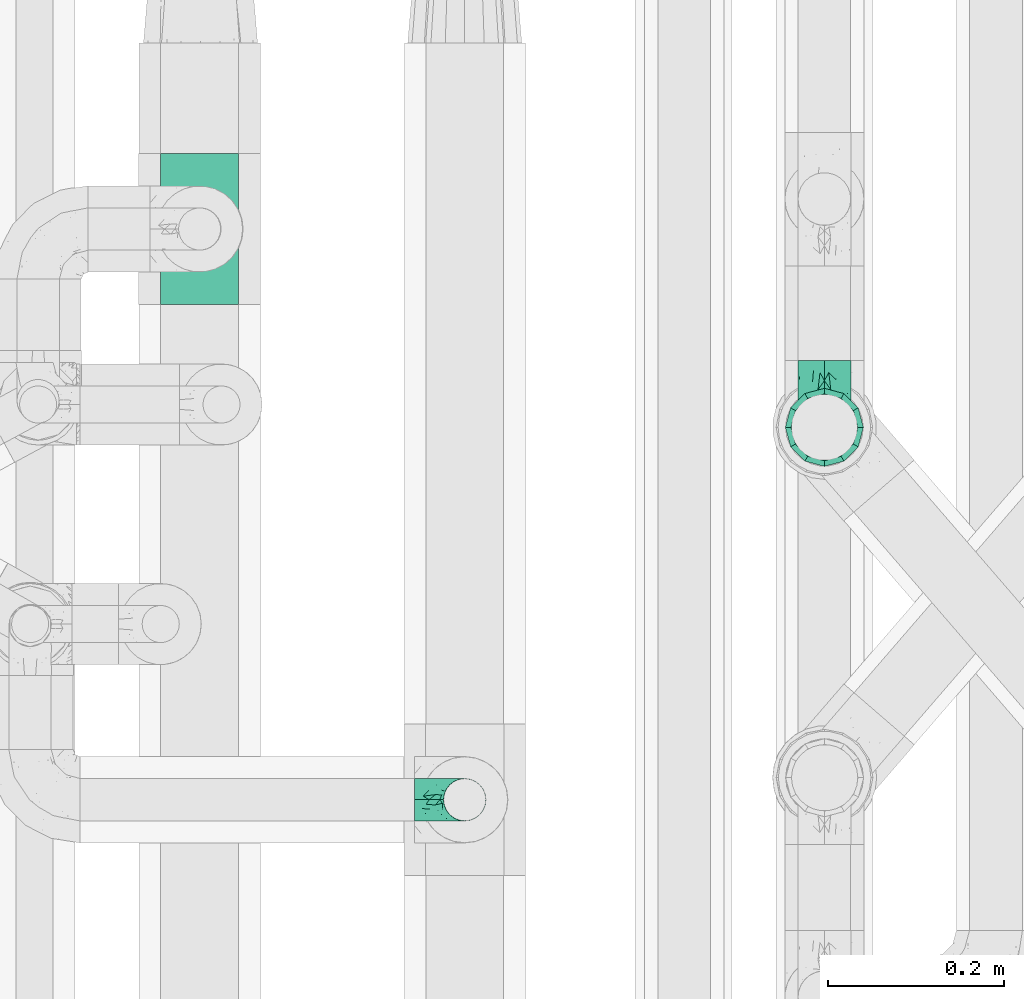
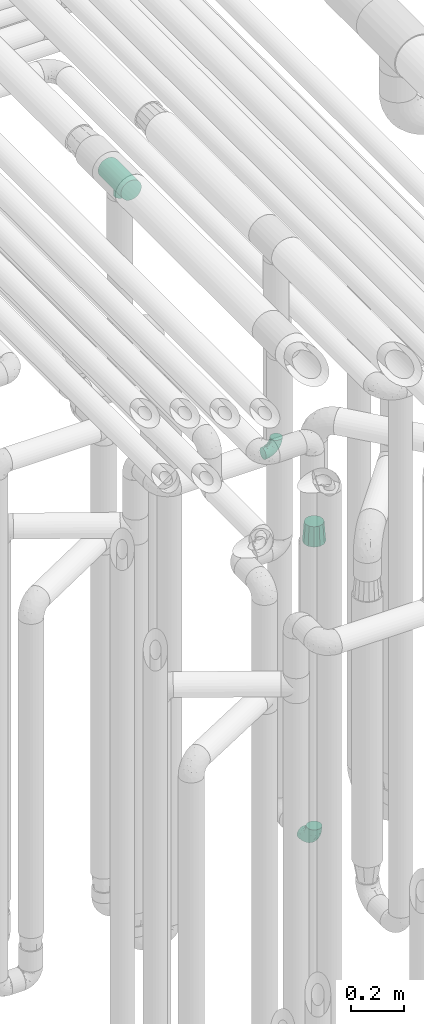
# One storey, part 623 of 824: 4 flow fittings.
"""IFC2X3 building model written with IfcOpenShell, lengths in millimetres."""

from ifc_helpers import new_model, entity, si_unit, converted_unit, derived_unit, direction, frame, origin, place, context, subcontext, project, spatial, faceted_brep, source, transform, mapped, material, type_object, type_shapes, element, save


model = new_model("IFC2X3")

# Units and contexts
model_context = context("Model", 3, precision=0.01, world=origin(), true_north=direction((6.12303176911189e-17, 1.0)))
body_context = subcontext(model_context, "Body", "Model", "MODEL_VIEW")
ifc_project = project(units=[si_unit("LENGTHUNIT", "METRE", prefix="MILLI"), si_unit("AREAUNIT", "SQUARE_METRE"), si_unit("VOLUMEUNIT", "CUBIC_METRE"), converted_unit("PLANEANGLEUNIT", "DEGREE", entity("IfcRatioMeasure", 0.0174532925199433), si_unit("PLANEANGLEUNIT", "RADIAN"), dimensions=[0, 0, 0, 0, 0, 0, 0]), si_unit("MASSUNIT", "GRAM", prefix="KILO"), derived_unit("MASSDENSITYUNIT", [(si_unit("MASSUNIT", "GRAM", prefix="KILO"), 1), (si_unit("LENGTHUNIT", "METRE"), -3)]), derived_unit("MOMENTOFINERTIAUNIT", [(si_unit("LENGTHUNIT", "METRE"), 4)]), si_unit("TIMEUNIT", "SECOND"), si_unit("FREQUENCYUNIT", "HERTZ"), si_unit("THERMODYNAMICTEMPERATUREUNIT", "DEGREE_CELSIUS"), derived_unit("THERMALTRANSMITTANCEUNIT", [(si_unit("MASSUNIT", "GRAM", prefix="KILO"), 1), (si_unit("THERMODYNAMICTEMPERATUREUNIT", "KELVIN"), -1), (si_unit("TIMEUNIT", "SECOND"), -3)]), derived_unit("VOLUMETRICFLOWRATEUNIT", [(si_unit("LENGTHUNIT", "METRE"), 3), (si_unit("TIMEUNIT", "SECOND"), -1)]), derived_unit("MASSFLOWRATEUNIT", [(si_unit("MASSUNIT", "GRAM", prefix="KILO"), 1), (si_unit("TIMEUNIT", "SECOND"), -1)]), derived_unit("ROTATIONALFREQUENCYUNIT", [(si_unit("TIMEUNIT", "SECOND"), -1)]), si_unit("ELECTRICCURRENTUNIT", "AMPERE"), si_unit("ELECTRICVOLTAGEUNIT", "VOLT"), si_unit("POWERUNIT", "WATT"), si_unit("FORCEUNIT", "NEWTON", prefix="KILO"), si_unit("ILLUMINANCEUNIT", "LUX"), si_unit("LUMINOUSFLUXUNIT", "LUMEN"), si_unit("LUMINOUSINTENSITYUNIT", "CANDELA"), derived_unit("USERDEFINED", [(si_unit("MASSUNIT", "GRAM", prefix="KILO"), -1), (si_unit("LENGTHUNIT", "METRE"), -2), (si_unit("TIMEUNIT", "SECOND"), 3), (si_unit("LUMINOUSFLUXUNIT", "LUMEN"), 1)]), derived_unit("LINEARVELOCITYUNIT", [(si_unit("LENGTHUNIT", "METRE"), 1), (si_unit("TIMEUNIT", "SECOND"), -1)]), si_unit("PRESSUREUNIT", "PASCAL"), derived_unit("USERDEFINED", [(si_unit("LENGTHUNIT", "METRE"), -2), (si_unit("MASSUNIT", "GRAM", prefix="KILO"), 1), (si_unit("TIMEUNIT", "SECOND"), -2)]), derived_unit("LINEARFORCEUNIT", [(si_unit("MASSUNIT", "GRAM", prefix="KILO"), 1), (si_unit("LENGTHUNIT", "METRE"), 1), (si_unit("TIMEUNIT", "SECOND"), -2), (si_unit("LENGTHUNIT", "METRE"), -1)]), derived_unit("PLANARFORCEUNIT", [(si_unit("MASSUNIT", "GRAM", prefix="KILO"), 1), (si_unit("LENGTHUNIT", "METRE"), 1), (si_unit("TIMEUNIT", "SECOND"), -2), (si_unit("LENGTHUNIT", "METRE"), -2)])], contexts=[model_context])

# Site, building, storey
site_placement = place(None, origin())
site = spatial("IfcSite", under=ifc_project, at=site_placement, CompositionType="ELEMENT")
building_placement = place(site_placement, origin())
building = spatial("IfcBuilding", under=site, at=building_placement, CompositionType="ELEMENT")
storey_placement = place(building_placement, frame((0.0, 0.0, 28200.0)))
storey = spatial("IfcBuildingStorey", under=building, at=storey_placement, CompositionType="ELEMENT", Elevation=28200.0)

# Flow fittings
ifc_material = material()
pipe_fitting_type_1 = type_object("IfcPipeFittingType", PredefinedType="NOTDEFINED", material=ifc_material)
shared_shape_1 = source(origin(), body_context, "Body", "Brep", [
    faceted_brep([(-57.0, 12.07, -20.91), (-57.0, 6.25, -23.33), (-57.0, 0.0, -24.15), (-57.0, -6.25, -23.33), (-57.0, -12.08, -20.91), (-57.0, -17.08, -17.08), (-57.0, -20.91, -12.08), (-57.0, -23.33, -6.25), (-57.0, -24.15, 0.0), (-57.0, -23.33, 6.25), (-57.0, -20.91, 12.07), (-57.0, -17.08, 17.08), (-57.0, -12.08, 20.91), (-57.0, -6.25, 23.33), (-57.0, 0.0, 24.15), (-57.0, 6.25, 23.33), (-57.0, 12.07, 20.91), (-57.0, 17.08, 17.08), (-57.0, 20.91, 12.07), (-57.0, 23.33, 6.25), (-57.0, 24.15, 0.0), (-57.0, 23.33, -6.25), (-57.0, 20.91, -12.08), (-57.0, 17.08, -17.08), (0.0, 57.0, -24.15), (-6.25, 57.0, -23.33), (-12.07, 57.0, -20.91), (-17.08, 57.0, -17.08), (-20.91, 57.0, -12.08), (-23.33, 57.0, -6.25), (-24.15, 57.0, 0.0), (-23.33, 57.0, 6.25), (-20.91, 57.0, 12.07), (-17.08, 57.0, 17.08), (-12.07, 57.0, 20.91), (-6.25, 57.0, 23.33), (0.0, 57.0, 24.15), (6.25, 57.0, 23.33), (12.08, 57.0, 20.91), (17.08, 57.0, 17.08), (20.91, 57.0, 12.07), (23.33, 57.0, 6.25), (24.15, 57.0, 0.0), (23.33, 57.0, -6.25), (20.91, 57.0, -12.08), (17.08, 57.0, -17.08), (12.08, 57.0, -20.91), (6.25, 57.0, -23.33), (14.9, 21.14, 6.17), (13.61, 24.64, 12.48), (6.23, 8.95, 8.98), (-41.47, -21.06, 0.0), (-41.92, -18.38, 13.72), (-24.64, -13.61, 12.48), (-37.37, -13.24, 18.15), (-6.8, -4.93, 8.18), (-21.76, -15.19, 6.22), (-12.78, -9.18, 0.0), (-37.73, -20.51, 7.75), (-7.38, 7.38, 20.24), (-23.37, -4.26, 20.42), (-11.9, -3.19, 15.86), (-42.14, -8.7, 21.82), (13.24, 37.37, 18.15), (9.33, 23.53, 16.85), (4.26, 23.37, 20.42), (2.77, 10.92, 15.55), (-29.46, 0.91, 23.52), (-44.13, 20.56, 15.69), (-39.25, 26.33, 10.88), (-49.02, 22.92, 9.96), (-34.58, 23.87, 17.15), (-15.8, 6.8, 22.81), (-8.67, 20.47, 23.88), (-18.12, 12.9, 24.08), (-48.29, 14.92, 19.65), (-44.06, -2.85, 23.78), (-9.23, 48.95, 22.58), (-3.78, 42.74, 24.07), (-40.34, 4.26, 24.09), (-44.02, 26.14, 5.46), (-44.04, 9.88, 22.74), (-4.95, 16.87, 22.52), (-2.75, 1.43, 12.5), (-25.48, 40.98, 10.71), (20.51, 37.73, 7.75), (18.38, 41.92, 13.72), (8.7, 42.14, 21.82), (-25.95, -17.97, 0.0), (2.85, 44.06, 23.78), (21.06, 41.47, 0.0), (17.97, 25.95, 0.0), (-24.04, -9.27, 17.13), (-33.26, 33.26, 5.86), (-28.55, 40.57, 0.0), (-40.57, 28.55, 0.0), (-25.29, 47.19, 4.06), (-27.01, 31.1, 16.77), (-15.7, 43.95, 19.9), (-20.27, 45.22, 15.61), (-30.53, 31.98, 12.64), (-11.28, 38.33, 22.92), (-9.97, 27.88, 24.09), (-20.15, 30.26, 21.25), (-31.25, 11.75, 23.64), (-28.75, 7.23, 24.15), (-29.53, 18.06, 22.27), (-28.44, 24.21, 20.02), (-37.55, 17.7, 20.26), (-15.88, 29.25, 22.99), (-20.82, 20.82, 23.44), (-0.91, 29.46, 23.52), (-13.5, -7.67, 12.04), (1.49, 1.56, 5.16), (8.86, 10.35, 4.59), (0.38, -0.38, 0.0), (9.18, 12.78, 0.0), (-37.37, -13.24, -18.15), (8.86, 10.35, -4.59), (-45.22, 20.27, -15.61), (-43.95, 15.7, -19.9), (-38.33, 11.28, -22.92), (-48.95, 9.23, -22.58), (-47.19, 25.29, -4.06), (-33.26, 33.26, -5.86), (18.38, 41.92, -13.72), (-30.26, 20.15, -21.25), (2.85, 44.06, -23.78), (-4.26, 40.34, -24.09), (-40.98, 25.48, -10.71), (-41.92, -18.38, -13.72), (9.25, 23.5, -16.92), (4.26, 23.37, -20.42), (13.24, 37.37, -18.15), (-37.73, -20.51, -7.75), (-11.75, 31.25, -23.64), (-7.23, 28.75, -24.15), (-12.9, 18.12, -24.08), (8.7, 42.14, -21.82), (-44.06, -2.85, -23.78), (-6.8, 15.8, -22.81), (-20.47, 8.67, -23.88), (-24.64, -13.61, -12.48), (-42.74, 3.78, -24.07), (-18.06, 29.53, -22.27), (-24.21, 28.44, -20.02), (-27.88, 9.97, -24.09), (-31.1, 27.01, -16.77), (-26.14, 44.02, -5.46), (14.9, 21.14, -6.17), (20.51, 37.73, -7.75), (-9.88, 44.04, -22.74), (-20.56, 44.13, -15.69), (-21.76, -15.19, -6.22), (-13.5, -7.67, -12.04), (-24.14, -9.76, -16.74), (-11.9, -3.19, -15.86), (-14.92, 48.29, -19.65), (-23.37, -4.26, -20.42), (-0.91, 29.46, -23.52), (-26.33, 39.25, -10.88), (-23.87, 34.58, -17.15), (-42.14, -8.7, -21.82), (-22.92, 49.02, -9.96), (13.61, 24.64, -12.48), (-31.98, 30.53, -12.64), (-16.87, 4.95, -22.52), (-17.7, 37.55, -20.26), (-29.25, 15.88, -22.99), (-20.82, 20.82, -23.44), (-29.46, 0.91, -23.52), (-7.38, 7.38, -20.24), (2.77, 10.92, -15.55), (6.23, 8.95, -8.98), (-6.8, -4.93, -8.18), (-2.81, 1.41, -12.54), (1.49, 1.56, -5.16)], [[[0, 1, 2, 3, 4, 5, 6, 7, 8, 9, 10, 11, 12, 13, 14, 15, 16, 17, 18, 19, 20, 21, 22, 23]], [[24, 25, 26, 27, 28, 29, 30, 31, 32, 33, 34, 35, 36, 37, 38, 39, 40, 41, 42, 43, 44, 45, 46, 47]], [[48, 49, 50]], [[9, 8, 51]], [[52, 53, 54]], [[55, 56, 57]], [[10, 58, 52]], [[9, 58, 10]], [[59, 60, 61]], [[54, 12, 11]], [[54, 62, 12]], [[63, 39, 38]], [[64, 65, 66]], [[62, 60, 67]], [[68, 69, 70]], [[71, 69, 68]], [[72, 73, 74]], [[16, 75, 17]], [[13, 76, 14]], [[35, 77, 78]], [[14, 79, 15]], [[17, 68, 18]], [[14, 76, 79]], [[20, 19, 80]], [[70, 19, 18]], [[81, 15, 79]], [[15, 81, 16]], [[73, 72, 82]], [[66, 83, 50]], [[32, 31, 84]], [[85, 86, 49]], [[63, 87, 65]], [[56, 58, 88]], [[36, 89, 37]], [[85, 41, 40]], [[36, 35, 78]], [[90, 41, 85]], [[40, 39, 86]], [[12, 62, 13]], [[86, 85, 40]], [[48, 85, 49]], [[85, 91, 90]], [[87, 38, 37]], [[92, 60, 54]], [[80, 69, 93]], [[93, 94, 95]], [[10, 52, 11]], [[94, 96, 30]], [[97, 98, 99]], [[80, 93, 95]], [[100, 97, 84]], [[99, 98, 33]], [[101, 102, 78]], [[103, 101, 98]], [[96, 31, 30]], [[77, 98, 101]], [[77, 35, 34]], [[34, 33, 98]], [[9, 51, 58]], [[87, 63, 38]], [[104, 105, 74]], [[106, 103, 107]], [[106, 81, 104]], [[75, 68, 17]], [[108, 107, 71]], [[33, 32, 99]], [[109, 103, 110]], [[101, 109, 102]], [[89, 78, 111]], [[53, 52, 58]], [[54, 11, 52]], [[60, 62, 54]], [[88, 58, 51]], [[76, 62, 67]], [[53, 112, 92]], [[60, 59, 72]], [[39, 63, 86]], [[49, 86, 63]], [[89, 87, 37]], [[42, 41, 90]], [[111, 82, 65]], [[111, 65, 87]], [[65, 59, 66]], [[104, 81, 79]], [[75, 81, 108]], [[32, 84, 99]], [[97, 99, 84]], [[98, 97, 103]], [[106, 107, 108]], [[74, 102, 110]], [[111, 78, 102]], [[74, 110, 104]], [[74, 67, 72]], [[61, 92, 112]], [[66, 59, 61]], [[56, 53, 58]], [[66, 50, 49]], [[61, 112, 83]], [[66, 49, 64]], [[78, 89, 36]], [[87, 89, 111]], [[62, 76, 13]], [[79, 76, 67]], [[100, 93, 69]], [[96, 93, 84]], [[55, 113, 50]], [[113, 114, 50]], [[104, 79, 105]], [[106, 104, 110]], [[20, 80, 95]], [[85, 48, 91]], [[115, 114, 113]], [[116, 91, 48]], [[70, 80, 19]], [[93, 96, 94]], [[84, 31, 96]], [[103, 106, 110]], [[81, 106, 108]], [[103, 97, 107]], [[71, 107, 97]], [[71, 97, 100]], [[108, 71, 68]], [[79, 67, 105]], [[67, 74, 105]], [[115, 113, 57]], [[112, 56, 55]], [[56, 88, 57]], [[60, 72, 67]], [[82, 72, 59]], [[65, 82, 59]], [[82, 111, 73]], [[111, 102, 73]], [[102, 74, 73]], [[81, 75, 16]], [[68, 75, 108]], [[68, 70, 18]], [[80, 70, 69]], [[98, 77, 34]], [[78, 77, 101]], [[93, 100, 84]], [[71, 100, 69]], [[102, 109, 110]], [[101, 103, 109]], [[53, 92, 54]], [[61, 60, 92]], [[56, 112, 53]], [[83, 112, 55]], [[50, 83, 55]], [[61, 83, 66]], [[49, 63, 64]], [[65, 64, 63]], [[57, 113, 55]], [[114, 115, 116]], [[116, 48, 114]], [[48, 50, 114]], [[117, 5, 4]], [[116, 115, 118]], [[119, 120, 23]], [[121, 122, 120]], [[95, 123, 20]], [[0, 23, 120]], [[124, 95, 94]], [[125, 45, 44]], [[121, 120, 126]], [[24, 127, 128]], [[22, 21, 129]], [[0, 122, 1]], [[5, 117, 130]], [[131, 132, 133]], [[134, 88, 51]], [[135, 136, 137]], [[6, 5, 130]], [[46, 138, 47]], [[139, 3, 2]], [[140, 141, 137]], [[6, 134, 7]], [[134, 130, 142]], [[143, 2, 1]], [[144, 126, 145]], [[121, 146, 143]], [[147, 120, 119]], [[94, 148, 124]], [[149, 150, 91]], [[30, 29, 148]], [[151, 25, 128]], [[27, 152, 28]], [[134, 153, 88]], [[154, 155, 156]], [[27, 26, 157]], [[151, 26, 25]], [[155, 158, 156]], [[24, 47, 127]], [[1, 122, 143]], [[138, 132, 159]], [[160, 152, 161]], [[24, 128, 25]], [[46, 133, 138]], [[162, 117, 4]], [[148, 160, 124]], [[152, 160, 163]], [[154, 142, 155]], [[45, 125, 133]], [[133, 46, 45]], [[125, 164, 133]], [[51, 7, 134]], [[42, 90, 43]], [[165, 147, 129]], [[153, 134, 142]], [[43, 150, 44]], [[162, 4, 3]], [[141, 140, 166]], [[117, 162, 158]], [[163, 29, 28]], [[43, 90, 150]], [[123, 21, 20]], [[144, 151, 135]], [[157, 152, 27]], [[167, 145, 161]], [[23, 22, 119]], [[168, 126, 169]], [[121, 168, 146]], [[139, 143, 170]], [[142, 130, 117]], [[8, 7, 51]], [[134, 6, 130]], [[139, 162, 3]], [[170, 166, 158]], [[170, 158, 162]], [[158, 171, 156]], [[44, 150, 125]], [[91, 150, 90]], [[164, 125, 150]], [[132, 138, 133]], [[127, 138, 159]], [[131, 164, 172]], [[132, 171, 140]], [[135, 151, 128]], [[157, 151, 167]], [[22, 129, 119]], [[147, 119, 129]], [[120, 147, 126]], [[144, 145, 167]], [[137, 146, 169]], [[170, 143, 146]], [[137, 169, 135]], [[137, 159, 140]], [[171, 172, 156]], [[173, 174, 175]], [[156, 175, 154]], [[174, 57, 153]], [[132, 172, 171]], [[172, 164, 173]], [[143, 139, 2]], [[162, 139, 170]], [[138, 127, 47]], [[128, 127, 159]], [[165, 124, 160]], [[123, 124, 129]], [[149, 173, 164]], [[176, 174, 173]], [[135, 128, 136]], [[144, 135, 169]], [[150, 149, 164]], [[176, 118, 115]], [[149, 91, 116]], [[30, 148, 94]], [[163, 148, 29]], [[124, 123, 95]], [[129, 21, 123]], [[126, 144, 169]], [[151, 144, 167]], [[126, 147, 145]], [[161, 145, 147]], [[161, 147, 165]], [[167, 161, 152]], [[128, 159, 136]], [[159, 137, 136]], [[154, 153, 142]], [[132, 140, 159]], [[174, 176, 57]], [[57, 88, 153]], [[166, 140, 171]], [[158, 166, 171]], [[166, 170, 141]], [[170, 146, 141]], [[146, 137, 141]], [[151, 157, 26]], [[152, 157, 167]], [[152, 163, 28]], [[148, 163, 160]], [[120, 122, 0]], [[143, 122, 121]], [[124, 165, 129]], [[161, 165, 160]], [[146, 168, 169]], [[121, 126, 168]], [[142, 117, 155]], [[158, 155, 117]], [[175, 156, 172]], [[153, 154, 174]], [[173, 175, 172]], [[174, 154, 175]], [[164, 131, 133]], [[172, 132, 131]], [[176, 173, 118]], [[57, 176, 115]], [[173, 149, 118]], [[149, 116, 118]]]),
])
type_shapes(pipe_fitting_type_1, [shared_shape_1])
flow_fitting_1_placement = place(storey_placement, frame((36220.03, 12556.08, 2600.0), z_axis=(0.0, -1.0, 0.0), x_axis=(1.0, 0.0, 0.0)))
element("IfcFlowFitting", 1, at=flow_fitting_1_placement, inside=storey, type_object=pipe_fitting_type_1, material=ifc_material, context=body_context, shape_type="MappedRepresentation", body=[
    mapped(shared_shape_1, transform((0.0, 0.0, 0.0), scale=1.0)),
])
pipe_fitting_type_2 = type_object("IfcPipeFittingType", PredefinedType="NOTDEFINED", material=ifc_material)
shared_shape_2 = source(origin(), body_context, "Body", "Brep", [
    faceted_brep([(-76.0, 15.07, -26.11), (-76.0, 7.8, -29.12), (-76.0, 0.0, -30.15), (-76.0, -7.8, -29.12), (-76.0, -15.08, -26.11), (-76.0, -21.32, -21.32), (-76.0, -26.11, -15.08), (-76.0, -29.12, -7.8), (-76.0, -30.15, 0.0), (-76.0, -29.12, 7.8), (-76.0, -26.11, 15.07), (-76.0, -21.32, 21.32), (-76.0, -15.08, 26.11), (-76.0, -7.8, 29.12), (-76.0, 0.0, 30.15), (-76.0, 7.8, 29.12), (-76.0, 15.07, 26.11), (-76.0, 21.32, 21.32), (-76.0, 26.11, 15.07), (-76.0, 29.12, 7.8), (-76.0, 30.15, 0.0), (-76.0, 29.12, -7.8), (-76.0, 26.11, -15.08), (-76.0, 21.32, -21.32), (0.0, 76.0, -30.15), (-7.8, 76.0, -29.12), (-15.07, 76.0, -26.11), (-21.32, 76.0, -21.32), (-26.11, 76.0, -15.08), (-29.12, 76.0, -7.8), (-30.15, 76.0, 0.0), (-29.12, 76.0, 7.8), (-26.11, 76.0, 15.07), (-21.32, 76.0, 21.32), (-15.07, 76.0, 26.11), (-7.8, 76.0, 29.12), (0.0, 76.0, 30.15), (7.8, 76.0, 29.12), (15.08, 76.0, 26.11), (21.32, 76.0, 21.32), (26.11, 76.0, 15.07), (29.12, 76.0, 7.8), (30.15, 76.0, 0.0), (29.12, 76.0, -7.8), (26.11, 76.0, -15.08), (21.32, 76.0, -21.32), (15.08, 76.0, -26.11), (7.8, 76.0, -29.12), (10.79, 31.43, 21.07), (4.32, 31.7, 25.72), (1.65, 15.19, 19.92), (-61.17, -27.8, 0.0), (-51.1, -25.49, 9.84), (-56.14, -10.61, 27.27), (-31.7, -4.32, 25.72), (-39.75, 1.72, 29.41), (-43.2, -24.95, 0.0), (-1.86, 1.86, 0.0), (4.49, 7.65, 5.78), (-7.82, -4.61, 5.83), (-56.21, -22.79, 17.21), (-58.98, -3.38, 29.7), (-53.96, 5.6, 30.07), (-10.86, 10.86, 25.48), (-17.2, -2.6, 20.44), (-49.15, -16.01, 22.7), (-22.18, -14.24, 7.99), (-28.4, -17.42, 0.0), (-13.61, -9.88, 0.0), (-39.0, 23.48, 27.76), (-58.76, 12.54, 28.36), (-41.61, 15.41, 29.48), (16.01, 49.15, 22.7), (-58.55, 25.93, 19.53), (-51.53, 33.5, 13.51), (-64.92, 28.76, 12.4), (-7.48, 23.14, 28.25), (-1.72, 39.75, 29.41), (-12.04, 27.88, 29.88), (-63.91, 18.81, 24.52), (-11.63, 65.16, 28.18), (-4.97, 57.02, 30.05), (9.88, 13.61, 0.0), (-62.5, 31.74, 5.02), (-45.17, 30.98, 21.2), (-21.78, 9.76, 28.58), (10.61, 56.14, 27.27), (-32.09, 54.42, 13.26), (22.79, 56.21, 17.21), (15.38, 31.17, 15.63), (25.49, 51.1, 9.84), (21.84, 36.35, 5.92), (24.95, 43.2, 0.0), (3.38, 58.98, 29.7), (-31.17, -15.38, 15.63), (-39.39, 41.78, 15.45), (-34.56, 41.13, 20.79), (-39.81, -23.25, 5.49), (27.8, 61.17, 0.0), (-31.74, 62.5, 5.02), (-53.07, 36.29, 0.0), (-42.95, 42.95, 7.29), (-36.29, 53.07, 0.0), (-19.83, 58.51, 24.79), (-25.48, 60.2, 19.41), (-14.53, 50.96, 28.57), (-13.31, 37.09, 30.07), (-26.16, 40.06, 26.4), (-32.43, -10.35, 21.9), (17.42, 28.4, 0.0), (14.24, 22.18, 7.99), (-38.67, 9.72, 30.15), (-24.66, 17.36, 30.09), (-37.08, 31.49, 24.99), (-49.27, 22.83, 25.24), (-20.8, 38.81, 28.63), (-27.58, 27.58, 29.2), (-36.07, -20.23, 10.71), (-15.19, -6.16, 14.9), (6.6, 15.4, 14.49), (-2.51, 2.51, 11.35), (-65.16, 11.63, -28.18), (-49.15, -16.01, -22.7), (-57.02, 4.97, -30.05), (-25.93, 58.55, -19.53), (-33.5, 51.53, -13.51), (-28.76, 64.92, -12.4), (-60.2, 25.48, -19.41), (-58.51, 19.83, -24.79), (4.61, 7.82, -5.83), (-7.65, -4.49, -5.78), (-2.51, 2.51, -11.35), (-62.5, 31.74, -5.02), (-50.96, 14.53, -28.57), (-37.09, 13.31, -30.07), (-42.95, 42.95, -7.29), (25.49, 51.1, -9.84), (22.79, 56.21, -17.21), (-40.06, 26.16, -26.4), (3.38, 58.98, -29.7), (-5.6, 53.96, -30.07), (-27.88, 12.04, -29.88), (-9.76, 21.78, -28.58), (-23.14, 7.48, -28.25), (-51.1, -25.49, -9.84), (15.38, 31.17, -15.63), (16.01, 49.15, -22.7), (-23.48, 39.0, -27.76), (-12.54, 58.76, -28.36), (-15.41, 41.61, -29.48), (-56.21, -22.79, -17.21), (-9.72, 38.67, -30.15), (-17.36, 24.66, -30.09), (-22.18, -14.24, -7.99), (-41.13, 34.56, -20.79), (-31.74, 62.5, -5.02), (-58.98, -3.38, -29.7), (-31.17, -15.38, -15.63), (-56.14, -10.61, -27.27), (14.24, 22.18, -7.99), (23.25, 39.81, -5.49), (-31.49, 37.08, -24.99), (-15.19, -6.16, -14.9), (1.65, 15.19, -19.92), (-18.81, 63.91, -24.52), (-32.59, -11.62, -20.84), (-31.7, -4.32, -25.72), (-17.2, -2.6, -20.44), (-39.75, 1.72, -29.41), (-54.42, 32.09, -13.26), (-30.98, 45.17, -21.2), (10.61, 56.14, -27.27), (10.23, 31.31, -21.52), (4.32, 31.7, -25.72), (-41.78, 39.39, -15.45), (-1.72, 39.75, -29.41), (-36.35, -21.84, -5.92), (-22.83, 49.27, -25.24), (-38.81, 20.8, -28.63), (-27.58, 27.58, -29.2), (-10.86, 10.86, -25.48), (20.23, 36.07, -10.71), (6.6, 15.4, -14.49)], [[[0, 1, 2, 3, 4, 5, 6, 7, 8, 9, 10, 11, 12, 13, 14, 15, 16, 17, 18, 19, 20, 21, 22, 23]], [[24, 25, 26, 27, 28, 29, 30, 31, 32, 33, 34, 35, 36, 37, 38, 39, 40, 41, 42, 43, 44, 45, 46, 47]], [[48, 49, 50]], [[51, 52, 9]], [[53, 54, 55]], [[9, 52, 10]], [[56, 52, 51]], [[57, 58, 59]], [[11, 10, 60]], [[14, 61, 62]], [[63, 54, 64]], [[65, 12, 11]], [[65, 53, 12]], [[66, 67, 68]], [[69, 70, 71]], [[72, 39, 38]], [[73, 74, 75]], [[15, 70, 16]], [[76, 77, 78]], [[16, 79, 17]], [[13, 61, 14]], [[35, 80, 81]], [[14, 62, 15]], [[17, 73, 18]], [[57, 82, 58]], [[20, 19, 83]], [[75, 19, 18]], [[70, 15, 62]], [[73, 84, 74]], [[78, 85, 76]], [[38, 86, 72]], [[32, 31, 87]], [[88, 89, 90]], [[91, 92, 90]], [[72, 86, 49]], [[36, 93, 37]], [[75, 83, 19]], [[36, 35, 81]], [[60, 94, 65]], [[40, 90, 41]], [[95, 96, 87]], [[88, 90, 40]], [[66, 97, 67]], [[90, 98, 41]], [[40, 39, 88]], [[99, 31, 30]], [[20, 83, 100]], [[101, 102, 100]], [[52, 60, 10]], [[102, 99, 30]], [[96, 103, 104]], [[83, 101, 100]], [[12, 53, 13]], [[104, 103, 33]], [[105, 106, 81]], [[107, 105, 103]], [[64, 54, 108]], [[80, 103, 105]], [[80, 35, 34]], [[34, 33, 103]], [[86, 38, 37]], [[109, 110, 82]], [[71, 111, 112]], [[69, 107, 113]], [[79, 73, 17]], [[114, 113, 84]], [[33, 32, 104]], [[115, 107, 116]], [[105, 115, 106]], [[93, 81, 77]], [[54, 53, 65]], [[61, 53, 55]], [[108, 94, 64]], [[54, 63, 85]], [[93, 86, 37]], [[77, 76, 49]], [[77, 49, 86]], [[49, 63, 50]], [[60, 52, 117]], [[65, 11, 60]], [[39, 72, 88]], [[89, 88, 72]], [[71, 70, 62]], [[79, 70, 114]], [[103, 96, 107]], [[69, 113, 114]], [[112, 106, 116]], [[77, 81, 106]], [[112, 116, 71]], [[112, 55, 85]], [[64, 50, 63]], [[57, 59, 68]], [[32, 87, 104]], [[96, 104, 87]], [[94, 118, 64]], [[50, 119, 89]], [[50, 64, 118]], [[50, 89, 48]], [[81, 93, 36]], [[86, 93, 77]], [[53, 61, 13]], [[62, 61, 55]], [[71, 62, 111]], [[69, 71, 116]], [[95, 101, 74]], [[99, 101, 87]], [[118, 66, 59]], [[117, 97, 66]], [[117, 66, 94]], [[91, 89, 110]], [[91, 110, 109]], [[110, 89, 119]], [[9, 8, 51]], [[98, 90, 92]], [[98, 42, 41]], [[101, 83, 74]], [[101, 99, 102]], [[87, 31, 99]], [[62, 55, 111]], [[55, 112, 111]], [[107, 69, 116]], [[70, 69, 114]], [[107, 96, 113]], [[84, 113, 96]], [[84, 96, 95]], [[114, 84, 73]], [[70, 79, 16]], [[73, 79, 114]], [[54, 85, 55]], [[76, 85, 63]], [[49, 76, 63]], [[77, 106, 78]], [[106, 112, 78]], [[85, 78, 112]], [[73, 75, 18]], [[83, 75, 74]], [[103, 80, 34]], [[81, 80, 105]], [[101, 95, 87]], [[84, 95, 74]], [[106, 115, 116]], [[105, 107, 115]], [[120, 59, 58]], [[82, 110, 58]], [[119, 58, 110]], [[118, 59, 120]], [[66, 68, 59]], [[54, 65, 108]], [[94, 108, 65]], [[66, 118, 94]], [[50, 118, 120]], [[50, 120, 119]], [[119, 120, 58]], [[89, 72, 48]], [[49, 48, 72]], [[60, 117, 94]], [[117, 52, 97]], [[52, 56, 97]], [[67, 97, 56]], [[92, 91, 109]], [[89, 91, 90]], [[121, 1, 0]], [[122, 5, 4]], [[2, 1, 123]], [[124, 125, 126]], [[127, 128, 23]], [[129, 130, 131]], [[100, 132, 20]], [[133, 134, 123]], [[135, 100, 102]], [[136, 137, 44]], [[133, 128, 138]], [[24, 139, 140]], [[141, 142, 143]], [[121, 128, 133]], [[6, 144, 7]], [[137, 145, 146]], [[144, 51, 7]], [[147, 148, 149]], [[144, 6, 150]], [[149, 151, 152]], [[153, 68, 67]], [[154, 128, 127]], [[30, 155, 102]], [[43, 42, 98]], [[156, 3, 2]], [[157, 144, 150]], [[158, 4, 3]], [[24, 140, 25]], [[155, 135, 102]], [[159, 160, 109]], [[30, 29, 155]], [[147, 138, 161]], [[27, 124, 28]], [[57, 129, 82]], [[162, 163, 131]], [[27, 26, 164]], [[148, 26, 25]], [[165, 166, 167]], [[24, 47, 139]], [[143, 168, 141]], [[22, 21, 169]], [[125, 124, 170]], [[148, 25, 140]], [[46, 146, 171]], [[158, 122, 4]], [[0, 23, 128]], [[1, 121, 123]], [[109, 82, 159]], [[45, 44, 137]], [[146, 46, 45]], [[136, 43, 98]], [[132, 21, 20]], [[136, 98, 92]], [[172, 173, 146]], [[46, 171, 47]], [[43, 136, 44]], [[174, 154, 169]], [[171, 173, 175]], [[6, 5, 150]], [[126, 29, 28]], [[176, 56, 144]], [[122, 158, 166]], [[164, 124, 27]], [[177, 161, 170]], [[23, 22, 127]], [[178, 138, 179]], [[133, 178, 134]], [[156, 123, 168]], [[156, 158, 3]], [[168, 143, 166]], [[168, 166, 158]], [[166, 180, 167]], [[173, 171, 146]], [[139, 171, 175]], [[172, 145, 163]], [[173, 180, 142]], [[5, 122, 150]], [[157, 150, 122]], [[137, 136, 181]], [[146, 45, 137]], [[149, 148, 140]], [[164, 148, 177]], [[128, 154, 138]], [[147, 161, 177]], [[152, 134, 179]], [[168, 123, 134]], [[152, 179, 149]], [[152, 175, 142]], [[57, 130, 129]], [[157, 165, 167]], [[22, 169, 127]], [[154, 127, 169]], [[163, 167, 180]], [[162, 157, 167]], [[173, 163, 180]], [[182, 163, 145]], [[123, 156, 2]], [[158, 156, 168]], [[171, 139, 47]], [[140, 139, 175]], [[149, 140, 151]], [[147, 149, 179]], [[174, 135, 125]], [[132, 135, 169]], [[176, 157, 153]], [[176, 153, 67]], [[153, 157, 162]], [[182, 159, 129]], [[181, 160, 159]], [[181, 159, 145]], [[51, 144, 56]], [[51, 8, 7]], [[135, 132, 100]], [[169, 21, 132]], [[126, 155, 29]], [[135, 155, 125]], [[140, 175, 151]], [[175, 152, 151]], [[138, 147, 179]], [[148, 147, 177]], [[138, 154, 161]], [[170, 161, 154]], [[170, 154, 174]], [[177, 170, 124]], [[148, 164, 26]], [[124, 164, 177]], [[173, 142, 175]], [[143, 142, 180]], [[166, 143, 180]], [[168, 134, 141]], [[134, 152, 141]], [[142, 141, 152]], [[124, 126, 28]], [[155, 126, 125]], [[128, 121, 0]], [[123, 121, 133]], [[135, 174, 169]], [[170, 174, 125]], [[134, 178, 179]], [[133, 138, 178]], [[130, 153, 162]], [[68, 153, 130]], [[57, 68, 130]], [[182, 129, 131]], [[159, 82, 129]], [[157, 122, 165]], [[166, 165, 122]], [[163, 162, 167]], [[162, 131, 130]], [[145, 172, 146]], [[163, 173, 172]], [[159, 182, 145]], [[131, 163, 182]], [[56, 176, 67]], [[157, 176, 144]], [[137, 181, 145]], [[181, 136, 160]], [[136, 92, 160]], [[109, 160, 92]]]),
])
type_shapes(pipe_fitting_type_2, [shared_shape_2])
flow_fitting_2_placement = place(storey_placement, frame((36629.64, 12980.2, 400.0), z_axis=(-1.0, 0.0, 0.0), x_axis=(0.0, -1.0, 0.0)))
element("IfcFlowFitting", 2, at=flow_fitting_2_placement, inside=storey, type_object=pipe_fitting_type_2, material=ifc_material, context=body_context, shape_type="MappedRepresentation", body=[
    mapped(shared_shape_2, transform((0.0, 0.0, 0.0), scale=1.0)),
])
pipe_fitting_type_3 = type_object("IfcPipeFittingType", PredefinedType="NOTDEFINED", material=ifc_material)
shared_shape_3 = source(origin(), body_context, "Body", "Brep", [
    faceted_brep([(89.0, -44.45, 0.0), (89.0, -41.96, -9.31), (89.0, -38.49, -22.22), (89.0, -30.36, -30.36), (89.0, -22.23, -38.49), (89.0, -11.11, -41.47), (89.0, 0.0, -44.45), (89.0, 11.11, -41.47), (89.0, 22.22, -38.49), (89.0, 30.36, -30.36), (89.0, 38.49, -22.22), (89.0, 41.96, -9.31), (89.0, 44.45, 0.0), (89.0, 41.96, 9.31), (89.0, 38.49, 22.23), (89.0, 30.36, 30.36), (89.0, 22.22, 38.49), (89.0, 11.11, 41.47), (89.0, 0.0, 44.45), (89.0, -11.11, 41.47), (89.0, -22.23, 38.49), (89.0, -30.36, 30.36), (89.0, -38.49, 22.23), (89.0, -41.96, 9.31), (0.0, 38.05, 0.0), (0.0, 35.5, -9.51), (0.0, 32.95, -19.02), (0.0, 25.99, -25.99), (0.0, 19.02, -32.95), (0.0, 9.51, -35.5), (0.0, 0.0, -38.05), (0.0, -9.51, -35.5), (0.0, -19.03, -32.95), (0.0, -25.99, -25.99), (0.0, -32.95, -19.02), (0.0, -35.5, -9.51), (0.0, -38.05, 0.0), (0.0, -35.5, 9.51), (0.0, -32.95, 19.03), (0.0, -25.99, 25.99), (0.0, -19.03, 32.95), (0.0, -9.51, 35.5), (0.0, 0.0, 38.05), (0.0, 9.51, 35.5), (0.0, 19.03, 32.95), (0.0, 25.99, 25.99), (0.0, 32.95, 19.03), (0.0, 35.5, 9.51)], [[[0, 1, 2, 3, 4, 5, 6, 7, 8, 9, 10, 11, 12, 13, 14, 15, 16, 17, 18, 19, 20, 21, 22, 23]], [[24, 25, 26, 27, 28, 29, 30, 31, 32, 33, 34, 35, 36, 37, 38, 39, 40, 41, 42, 43, 44, 45, 46, 47]], [[2, 1, 0, 36, 35, 34]], [[28, 8, 7, 6, 30, 29]], [[32, 4, 3, 2, 34, 33]], [[5, 4, 32, 31, 30, 6]], [[10, 26, 25, 24, 12, 11]], [[9, 8, 28, 27, 26, 10]], [[14, 13, 12, 24, 47, 46]], [[40, 20, 19, 18, 42, 41]], [[44, 16, 15, 14, 46, 45]], [[17, 16, 44, 43, 42, 18]], [[22, 38, 37, 36, 0, 23]], [[21, 20, 40, 39, 38, 22]]]),
])
type_shapes(pipe_fitting_type_3, [shared_shape_3])
flow_fitting_3_placement = place(storey_placement, frame((36629.64, 12980.2, 1870.0), z_axis=(0.0, 1.0, 0.0), x_axis=(0.0, 0.0, -1.0)))
element("IfcFlowFitting", 3, at=flow_fitting_3_placement, inside=storey, type_object=pipe_fitting_type_3, material=ifc_material, context=body_context, shape_type="MappedRepresentation", body=[
    mapped(shared_shape_3, transform((0.0, 0.0, 0.0), scale=1.0)),
])
pipe_fitting_type_4 = type_object("IfcPipeFittingType", PredefinedType="NOTDEFINED", material=ifc_material)
shared_shape_4 = source(origin(), body_context, "Body", "Brep", [
    faceted_brep([(-86.0, 22.22, -38.49), (-86.0, 11.5, -42.94), (-86.0, 0.0, -44.45), (-86.0, -11.5, -42.94), (-86.0, -22.23, -38.49), (-86.0, -31.43, -31.43), (-86.0, -38.49, -22.23), (-86.0, -42.94, -11.5), (-86.0, -44.45, 0.0), (-86.0, -42.94, 11.5), (-86.0, -38.49, 22.22), (-86.0, -31.43, 31.43), (-86.0, -22.23, 38.49), (-86.0, -11.5, 42.94), (-86.0, 0.0, 44.45), (-86.0, 11.5, 42.94), (-86.0, 22.22, 38.49), (-86.0, 31.43, 31.43), (-86.0, 38.49, 22.22), (-86.0, 42.94, 11.5), (-86.0, 44.45, 0.0), (-86.0, 42.94, -11.5), (-86.0, 38.49, -22.23), (-86.0, 31.43, -31.43), (86.0, 0.0, -44.45), (86.0, 11.5, -42.94), (86.0, 22.22, -38.49), (86.0, 31.43, -31.43), (86.0, 38.49, -22.23), (86.0, 42.94, -11.5), (86.0, 44.45, 0.0), (86.0, 42.94, 11.5), (86.0, 38.49, 22.22), (86.0, 31.43, 31.43), (86.0, 22.22, 38.49), (86.0, 11.5, 42.94), (86.0, 0.0, 44.45), (86.0, -11.5, 42.94), (86.0, -22.23, 38.49), (86.0, -31.43, 31.43), (86.0, -38.49, 22.22), (86.0, -42.94, 11.5), (86.0, -44.45, 0.0), (86.0, -42.94, -11.5), (86.0, -38.49, -22.23), (86.0, -31.43, -31.43), (86.0, -22.23, -38.49), (86.0, -11.5, -42.94), (22.65, -43.65, 8.39), (23.4, -44.05, 4.19), (24.15, -44.45, 0.0), (18.45, -41.63, 15.58), (4.27, -37.56, 23.77), (12.15, -39.25, 20.87), (8.21, -38.4, 22.32), (-24.15, -44.45, 0.0), (-23.4, -44.05, 4.19), (-22.65, -43.65, 8.38), (-18.46, -41.63, 15.57), (-12.16, -39.25, 20.87), (-8.22, -38.4, 22.32), (-4.28, -37.56, 23.77), (0.0, -37.56, 23.77), (4.27, -37.56, -23.77), (12.15, -39.25, -20.87), (8.21, -38.4, -22.32), (18.45, -41.63, -15.58), (22.65, -43.65, -8.39), (23.4, -44.05, -4.19), (-4.28, -37.56, -23.77), (-8.22, -38.4, -22.32), (-12.16, -39.25, -20.87), (-18.46, -41.63, -15.57), (0.0, -37.56, -23.77), (-22.65, -43.65, -8.38), (-23.4, -44.05, -4.19), (0.0, -73.0, -24.15), (6.25, -73.0, -23.33), (12.08, -73.0, -20.91), (17.08, -73.0, -17.08), (20.91, -73.0, -12.08), (23.33, -73.0, -6.25), (24.15, -73.0, 0.0), (23.33, -73.0, 6.25), (20.91, -73.0, 12.07), (17.08, -73.0, 17.08), (12.08, -73.0, 20.91), (6.25, -73.0, 23.33), (0.0, -73.0, 24.15), (-6.25, -73.0, 23.33), (-12.07, -73.0, 20.91), (-17.08, -73.0, 17.08), (-20.91, -73.0, 12.07), (-23.33, -73.0, 6.25), (-24.15, -73.0, 0.0), (-23.33, -73.0, -6.25), (-20.91, -73.0, -12.08), (-17.08, -73.0, -17.08), (-12.07, -73.0, -20.91), (-6.25, -73.0, -23.33)], [[[0, 1, 2, 3, 4, 5, 6, 7, 8, 9, 10, 11, 12, 13, 14, 15, 16, 17, 18, 19, 20, 21, 22, 23]], [[24, 25, 26, 27, 28, 29, 30, 31, 32, 33, 34, 35, 36, 37, 38, 39, 40, 41, 42, 43, 44, 45, 46, 47]], [[42, 41, 48]], [[42, 48, 49, 50]], [[41, 51, 48]], [[40, 39, 52]], [[53, 51, 40]], [[40, 52, 54, 53]], [[39, 11, 52]], [[40, 51, 41]], [[8, 55, 56, 57]], [[9, 8, 57]], [[57, 58, 9]], [[10, 59, 60, 61]], [[59, 10, 58]], [[10, 61, 11]], [[58, 10, 9]], [[11, 61, 62, 52]], [[39, 38, 12, 11]], [[14, 13, 37, 36]], [[13, 12, 38, 37]], [[15, 14, 36, 35]], [[32, 31, 19, 18]], [[17, 16, 34, 33]], [[18, 17, 33, 32]], [[35, 34, 16, 15]], [[20, 19, 31, 30]], [[29, 28, 22, 21]], [[28, 27, 23, 22]], [[30, 29, 21, 20]], [[24, 47, 3, 2]], [[1, 0, 26, 25]], [[2, 1, 25, 24]], [[27, 26, 0, 23]], [[4, 3, 47, 46]], [[46, 45, 5, 4]], [[45, 44, 63]], [[44, 64, 65, 63]], [[44, 66, 64]], [[45, 63, 5]], [[43, 42, 67]], [[67, 66, 43]], [[42, 50, 68, 67]], [[43, 66, 44]], [[6, 69, 70, 71]], [[6, 5, 69]], [[71, 72, 6]], [[5, 63, 73, 69]], [[72, 74, 7]], [[74, 8, 7]], [[8, 74, 75, 55]], [[72, 7, 6]], [[76, 77, 78, 79, 80, 81, 82, 83, 84, 85, 86, 87, 88, 89, 90, 91, 92, 93, 94, 95, 96, 97, 98, 99]], [[93, 56, 94]], [[88, 61, 89]], [[60, 90, 89]], [[60, 59, 90]], [[86, 54, 87]], [[93, 57, 56]], [[49, 82, 50]], [[57, 93, 92]], [[56, 55, 94]], [[57, 92, 58]], [[90, 59, 91]], [[89, 61, 60]], [[91, 59, 58]], [[91, 58, 92]], [[88, 52, 62, 61]], [[86, 53, 54]], [[85, 53, 86]], [[48, 84, 83]], [[85, 84, 51]], [[52, 88, 87]], [[54, 52, 87]], [[53, 85, 51]], [[51, 84, 48]], [[82, 49, 83]], [[49, 48, 83]], [[81, 68, 82]], [[79, 66, 80]], [[65, 64, 78]], [[81, 67, 68]], [[80, 67, 81]], [[64, 79, 78]], [[68, 50, 82]], [[67, 80, 66]], [[77, 63, 65]], [[64, 66, 79]], [[76, 69, 73, 63]], [[98, 70, 99]], [[75, 94, 55]], [[98, 71, 70]], [[76, 63, 77]], [[75, 74, 95]], [[97, 71, 98]], [[74, 96, 95]], [[97, 96, 72]], [[69, 76, 99]], [[70, 69, 99]], [[71, 97, 72]], [[72, 96, 74]], [[94, 75, 95]], [[65, 78, 77]]]),
])
type_shapes(pipe_fitting_type_4, [shared_shape_4])
flow_fitting_4_placement = place(storey_placement, frame((35918.07, 13206.08, 3550.0), z_axis=(1.0, 0.0, 0.0), x_axis=(0.0, 1.0, -9.11558797326423e-08)))
element("IfcFlowFitting", 4, at=flow_fitting_4_placement, inside=storey, type_object=pipe_fitting_type_4, material=ifc_material, context=body_context, shape_type="MappedRepresentation", body=[
    mapped(shared_shape_4, transform((0.0, 0.0, 0.0), scale=1.0)),
])

save(model, "model.ifc")
